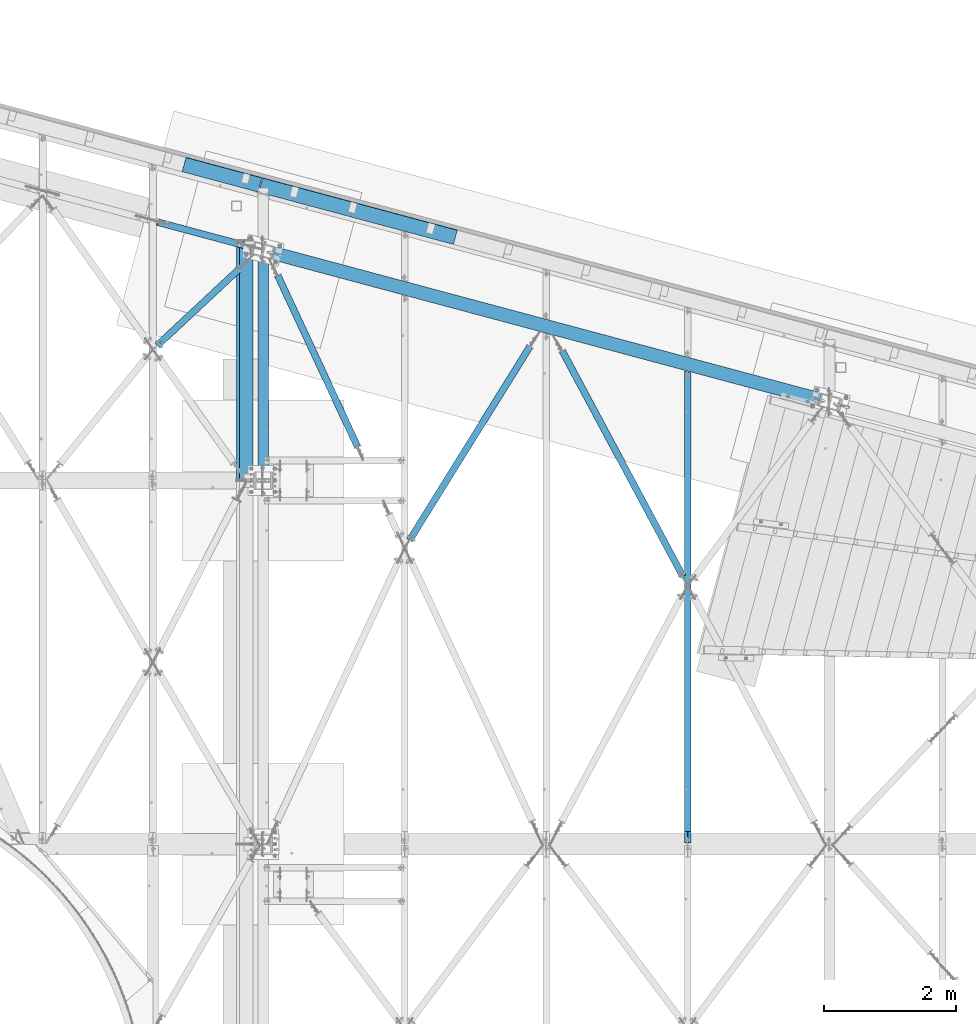
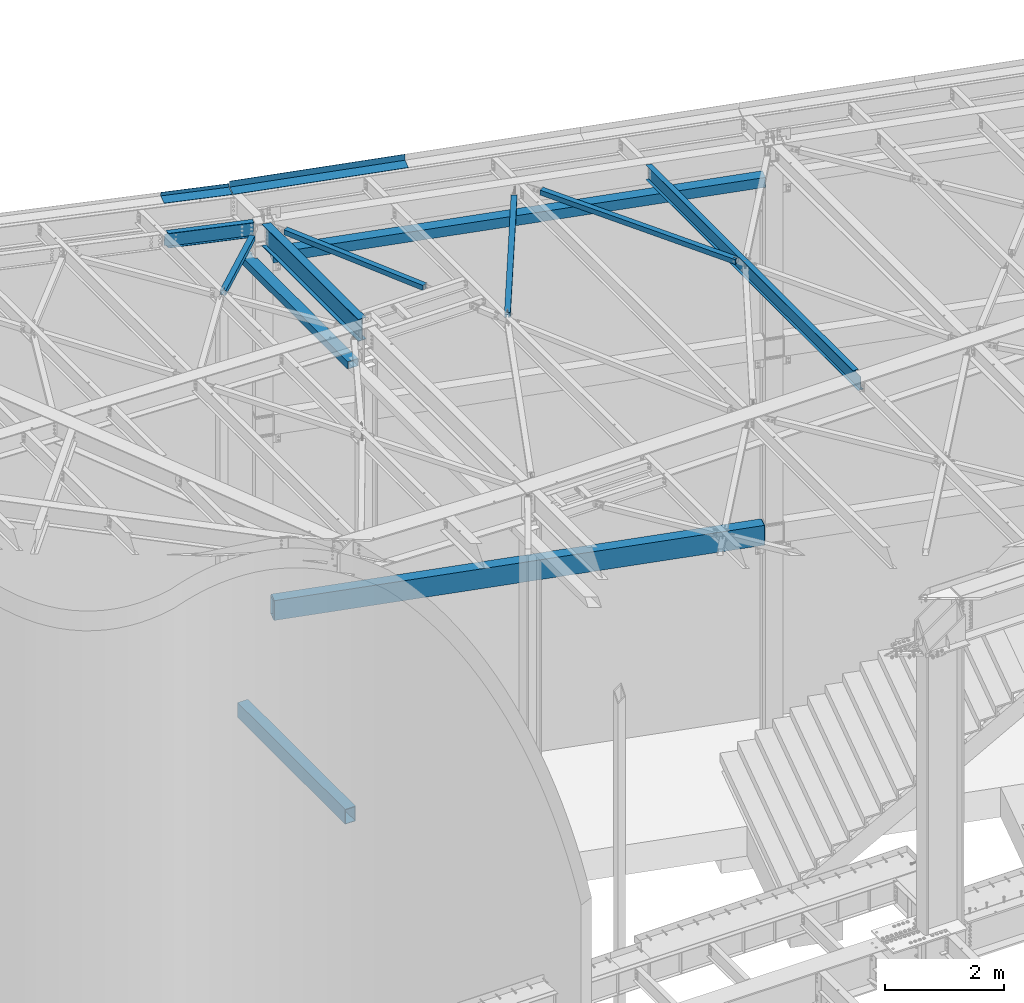
# One storey, part 1159 of 1763: 13 beams, 13 elements without a shape of their own.
"""IFC2X3 building model written with IfcOpenShell, lengths in millimetres."""

from ifc_helpers import new_model, si_unit, frame, origin_with_axes, place, context, subcontext, project, spatial, faceted_brep, material, type_object, element, aggregate, save


model = new_model("IFC2X3")

# Units and contexts
model_context = context("Model", 3, precision=1e-05, world=origin_with_axes())
body_context = subcontext(model_context, "Body", "Model", "MODEL_VIEW")
ifc_project = project(units=[si_unit("LENGTHUNIT", "METRE", prefix="MILLI"), si_unit("AREAUNIT", "SQUARE_METRE"), si_unit("VOLUMEUNIT", "CUBIC_METRE"), si_unit("MASSUNIT", "GRAM", prefix="KILO"), si_unit("TIMEUNIT", "SECOND"), si_unit("PLANEANGLEUNIT", "RADIAN"), si_unit("SOLIDANGLEUNIT", "STERADIAN"), si_unit("THERMODYNAMICTEMPERATUREUNIT", "DEGREE_CELSIUS"), si_unit("LUMINOUSINTENSITYUNIT", "LUMEN")], contexts=[model_context])

# Site, building, storey
site_placement = place(None, origin_with_axes())
site = spatial("IfcSite", under=ifc_project, at=site_placement, CompositionType="ELEMENT")
building_placement = place(site_placement, origin_with_axes())
building = spatial("IfcBuilding", under=site, at=building_placement, Name="Undefined", CompositionType="ELEMENT")
storey_placement = place(building_placement, origin_with_axes())
storey = spatial("IfcBuildingStorey", under=building, at=storey_placement, Name="Undefined", CompositionType="ELEMENT", Elevation=0.0)

# Assembly, beam
assembly_1_placement = place(storey_placement, origin_with_axes())
assembly_1 = element("IfcElementAssembly", 1, at=assembly_1_placement, inside=storey, Name="BEAM", AssemblyPlace="NOTDEFINED", PredefinedType="RIGID_FRAME")
ifc_material_1 = material()
beam_type_1 = type_object("IfcBeamType", Name="HSS8X8X3/8", PredefinedType="NOTDEFINED")
beam_1_placement = place(assembly_1_placement, frame((-39672.2896173963, 66681.4025701043, 11699.875), z_axis=(0.0, 0.0, 1.0), x_axis=(0.965925826295336, -0.25881904507913, 0.0)))
beam_1 = element("IfcBeam", 2, at=beam_1_placement, type_object=beam_type_1, material=ifc_material_1, Name="BEAM", ObjectType="HSS8X8X3/8", context=body_context, shape_type="Brep", body=[
    faceted_brep([(152.404929528384, 92.0750000005864, -92.0750000000007), (152.404929527896, -92.0749999999898, -92.0750000000007), (8712.52908409735, -92.0749999837644, -92.0750000000007), (8712.52908409783, 92.0750000168191, -92.0750000000007), (152.404929527896, -92.0749999999898, 92.0750000000007), (8712.52908409735, -92.0749999837644, 92.0750000000007), (152.404929528384, 92.0750000005864, 92.0750000000007), (8712.52908409783, 92.0750000168191, 92.0750000000007), (152.404929528398, 101.600000000624, -101.6), (152.404929528398, 101.600000000624, 101.6), (8712.52908409786, 101.600000016842, 101.6), (8712.52908409786, 101.600000016842, -101.6), (152.404929527875, -101.60000000002, 101.6), (8712.52908409732, -101.59999998378, 101.6), (152.404929527875, -101.60000000002, -101.6), (8712.52908409732, -101.59999998378, -101.6)], [[[0, 1, 2, 3]], [[1, 4, 5, 2]], [[4, 6, 7, 5]], [[6, 0, 3, 7]], [[8, 9, 10, 11]], [[9, 12, 13, 10]], [[12, 14, 15, 13]], [[14, 8, 11, 15]], [[13, 15, 11, 10], [5, 7, 3, 2]], [[14, 12, 9, 8], [6, 4, 1, 0]]]),
])
aggregate(assembly_1, [beam_1])

assembly_2_placement = place(storey_placement, origin_with_axes())
assembly_2 = element("IfcElementAssembly", 3, at=assembly_2_placement, inside=storey, Name="BEAM", AssemblyPlace="NOTDEFINED", PredefinedType="RIGID_FRAME")
beam_type_2 = type_object("IfcBeamType", Name="HSS16X8X5/8", PredefinedType="NOTDEFINED")
beam_2_placement = place(assembly_2_placement, frame((-39672.2896174423, 66681.4025701167, 4470.4), z_axis=(0.0, 0.0, 1.0), x_axis=(0.965925826295336, -0.25881904507913, 0.0)))
beam_2 = element("IfcBeam", 4, at=beam_2_placement, type_object=beam_type_2, material=ifc_material_1, Name="BEAM", ObjectType="HSS16X8X5/8", context=body_context, shape_type="Brep", body=[
    faceted_brep([(174.629929660281, 101.600000000712, 203.2), (174.629929640418, 101.600000000726, -203.2), (158.754929640003, 85.7250000006388, -187.325), (158.754929640003, 85.7250000006388, 187.325), (174.629929639552, -101.599999999729, -203.2), (158.754929640003, -85.7249999997366, -187.325), (174.629929646464, -101.600000007791, 203.200000005744), (158.754929640003, -85.7249999997366, 187.325), (8704.59949159464, -85.7249999754858, -187.325), (8688.72449160701, -101.599999975559, -203.2), (8688.7244915844, 101.600000024882, -203.2), (8704.59949159464, 85.7250000248896, -187.325), (8704.59949160298, -85.7249999917767, 187.324999992047), (8688.72449157427, -101.599999975573, 203.2), (8704.59949159464, 85.7250000248896, 187.325), (8688.72449157427, 101.600000024882, 203.2)], [[[0, 1, 2, 3]], [[4, 5, 2, 1]], [[6, 7, 5, 4]], [[8, 9, 10, 11]], [[12, 13, 9, 8]], [[14, 15, 13, 12]], [[13, 15, 0, 6]], [[9, 13, 6, 4]], [[10, 9, 4, 1]], [[15, 10, 1, 0]], [[14, 11, 10, 15]], [[11, 14, 3, 2]], [[8, 11, 2, 5]], [[12, 8, 5, 7]], [[14, 12, 7, 3]], [[0, 3, 7, 6]]]),
])
aggregate(assembly_2, [beam_2])

assembly_3_placement = place(storey_placement, origin_with_axes())
assembly_3 = element("IfcElementAssembly", 5, at=assembly_3_placement, inside=storey, Name="H. BRACE", AssemblyPlace="NOTDEFINED", PredefinedType="RIGID_FRAME")
beam_type_3 = type_object("IfcBeamType", Name="HSS4X4X3/8", PredefinedType="NOTDEFINED")
beam_3_placement = place(assembly_3_placement, frame((-38149.0745035581, 63506.3499999925, 12371.3875), z_axis=(0.0, 0.0, 1.0), x_axis=(-0.422551799059311, 0.906338776127194, 0.0)))
beam_3 = element("IfcBeam", 6, at=beam_3_placement, type_object=beam_type_3, material=ifc_material_1, Name="H. BRACE", ObjectType="HSS4X4X3/8", context=body_context, shape_type="Brep", body=[
    faceted_brep([(227.966473996188, 41.2749999993148, -41.2749999999996), (227.966473996188, -41.2750000005753, -41.2749999999996), (3079.83416805277, -41.2750000083643, -41.2749999999996), (3079.83416797796, 41.2749999915186, -41.2749999999996), (227.966473996188, -41.2750000005753, 41.2749999999996), (3079.83416805277, -41.2750000083643, 41.2749999999996), (227.966473996188, 41.2749999993148, 41.2749999999996), (3079.83416797796, 41.2749999915186, 41.2749999999996), (227.966473996188, 50.7999999993017, -50.7999999999993), (227.966473996188, 50.7999999993017, 50.7999999999993), (3079.83416796933, 50.7999999915128, 50.7999999999993), (3079.83416796933, 50.7999999915128, -50.7999999999993), (227.966473996188, -50.800000000555, 50.7999999999993), (3079.8341680614, -50.8000000083475, 50.7999999999993), (227.966473996188, -50.800000000555, -50.7999999999993), (3079.8341680614, -50.8000000083475, -50.7999999999993)], [[[0, 1, 2, 3]], [[1, 4, 5, 2]], [[4, 6, 7, 5]], [[6, 0, 3, 7]], [[8, 9, 10, 11]], [[9, 12, 13, 10]], [[12, 14, 15, 13]], [[14, 8, 11, 15]], [[13, 15, 11, 10], [5, 7, 3, 2]], [[14, 12, 9, 8], [6, 4, 1, 0]]]),
])
aggregate(assembly_3, [beam_3])

assembly_4_placement = place(storey_placement, origin_with_axes())
assembly_4 = element("IfcElementAssembly", 7, at=assembly_4_placement, inside=storey, Name="H. BRACE", AssemblyPlace="NOTDEFINED", PredefinedType="RIGID_FRAME")
beam_4_placement = place(assembly_4_placement, frame((-33252.4396171231, 61613.3086276461, 12371.3875), z_axis=(0.0, 0.0, 1.0), x_axis=(-0.471735585214394, 0.881740062400724, 0.0)))
beam_4 = element("IfcBeam", 8, at=beam_4_placement, type_object=beam_type_3, material=ifc_material_1, Name="H. BRACE", ObjectType="HSS4X4X3/8", context=body_context, shape_type="Brep", body=[
    faceted_brep([(155.52652332226, 6.35000247701464, 50.7999999999993), (155.52652332226, 6.35000247701464, 41.2749999999996), (233.119734693653, 6.34999997572231, 41.2749999999996), (233.119734693653, 6.34999997572231, 50.7999999999993), (233.11973428425, -6.35000002432571, 50.7999999999993), (233.11973428425, -6.35000002432571, 41.2749999999996), (155.52652332226, -6.34999752304066, 41.2749999999996), (155.52652332226, -6.34999752304066, 50.7999999999993), (155.52652332226, 6.35000247701464, -41.2749999999996), (155.52652332226, 6.35000247701464, -50.7999999999993), (233.119734693653, 6.34999997572231, -50.7999999999993), (233.119734693653, 6.34999997572231, -41.2749999999996), (233.11973428425, -6.35000002432571, -41.2749999999996), (233.11973428425, -6.35000002432571, -50.7999999999993), (155.52652332226, -6.34999752304066, -50.7999999999993), (155.52652332226, -6.34999752304066, -41.2749999999996), (155.52652332226, -41.2750000005617, -41.2749999999996), (155.52652332226, -41.2750000005617, 41.2749999999996), (4016.93462155541, -41.2750000137494, 41.2749999999996), (4016.93462155541, -41.2750000137494, -41.2749999999996), (155.52652332226, 50.7999999995045, -50.7999999999993), (4016.93462155541, 50.7999999863132, -50.7999999999993), (4016.93462155541, -50.8000000137581, -50.7999999999993), (155.52652332226, -50.8000000005704, -50.7999999999993), (155.52652332226, -50.8000000005704, 50.7999999999993), (4016.93462155541, -50.8000000137581, 50.7999999999993), (155.52652332226, 41.2749999994958, 41.2749999999996), (4016.93462155541, 41.2749999863117, 41.2749999999996), (155.52652332226, 41.2749999994958, -41.2749999999996), (4016.93462155541, 41.2749999863117, -41.2749999999996), (4016.93462155541, 50.7999999863132, 50.7999999999993), (155.52652332226, 50.7999999995045, 50.7999999999993)], [[[0, 1, 2, 3]], [[4, 5, 6, 7]], [[3, 2, 5, 4]], [[8, 9, 10, 11]], [[12, 13, 14, 15]], [[11, 10, 13, 12]], [[16, 17, 18, 19]], [[9, 20, 21, 22, 23, 14, 13, 10]], [[24, 23, 22, 25]], [[17, 16, 15, 14, 23, 24, 7, 6]], [[1, 26, 27, 18, 17, 6, 5, 2]], [[26, 28, 29, 27]], [[25, 22, 21, 30], [18, 27, 29, 19]], [[20, 31, 30, 21]], [[24, 25, 30, 31, 0, 3, 4, 7]], [[31, 20, 9, 8, 28, 26, 1, 0]], [[16, 19, 29, 28, 8, 11, 12, 15]]]),
])
aggregate(assembly_4, [beam_4])

assembly_5_placement = place(storey_placement, origin_with_axes())
assembly_5 = element("IfcElementAssembly", 9, at=assembly_5_placement, inside=storey, Name="H. BRACE", AssemblyPlace="NOTDEFINED", PredefinedType="RIGID_FRAME")
beam_5_placement = place(assembly_5_placement, frame((-39721.2091356066, 66694.510515489, 12382.5), z_axis=(0.0, 0.0, 1.0), x_axis=(-0.730932691702621, -0.682449558722372, 0.0)))
beam_5 = element("IfcBeam", 10, at=beam_5_placement, type_object=beam_type_3, material=ifc_material_1, Name="H. BRACE", ObjectType="HSS4X4X3/8", context=body_context, shape_type="Brep", body=[
    faceted_brep([(2126.16793068792, 6.3500000040076, 50.7999999999993), (2048.38043068183, 6.35000000408036, 50.7999999999993), (2048.38043068183, 6.35000000408036, 41.2749999999996), (2126.16793068792, 6.3500000040076, 41.2749999999996), (2048.38043068182, -6.34999999585852, 50.7999999999993), (2048.38043068182, -6.34999999585852, 41.2749999999996), (2126.16793068792, -6.34999999593128, 50.7999999999993), (2126.16793068792, -6.34999999593128, 41.2749999999996), (2126.16793068792, 6.3500000040076, -41.2749999999996), (2048.38043068183, 6.35000000408036, -41.2749999999996), (2048.38043068183, 6.35000000408036, -50.7999999999993), (2126.16793068792, 6.3500000040076, -50.7999999999993), (2048.38043068182, -6.34999999585852, -41.2749999999996), (2048.38043068182, -6.34999999585852, -50.7999999999993), (2126.16793068792, -6.34999999593128, -41.2749999999996), (2126.16793068792, -6.34999999593128, -50.7999999999993), (446.776849324, 41.2749999995867, 41.2749999999996), (446.776849324, 41.2749999995867, -41.2749999999996), (2126.16793068792, 41.2749999982043, -41.2749999999996), (2126.16793068792, 41.2749999982043, 41.2749999999996), (2126.16793068792, -41.2750000016531, 41.2749999999996), (446.776849324, -41.2750000002998, 41.2749999999996), (446.776849324, -41.2750000002998, -41.2749999999996), (2126.16793068792, -41.2750000016531, -41.2749999999996), (446.776849323996, -50.8000000002794, -50.7999999999993), (446.776849323996, -50.8000000002794, 50.7999999999993), (446.776849324, 50.7999999995518, 50.7999999999993), (446.776849324, 50.7999999995518, -50.7999999999993), (2126.16793068792, 50.7999999981985, 50.7999999999993), (2126.16793068792, 50.7999999981985, -50.7999999999993), (2126.16793068792, -50.8000000016473, -50.7999999999993), (2126.16793068792, -50.8000000016473, 50.7999999999993)], [[[0, 1, 2, 3]], [[4, 5, 2, 1]], [[6, 7, 5, 4]], [[8, 9, 10, 11]], [[12, 13, 10, 9]], [[14, 15, 13, 12]], [[16, 17, 18, 19]], [[20, 21, 16, 19, 3, 2, 5, 7]], [[22, 21, 20, 23]], [[9, 8, 18, 17, 22, 23, 14, 12]], [[24, 25, 26, 27], [16, 21, 22, 17]], [[27, 26, 28, 29]], [[19, 18, 8, 11, 29, 28, 0, 3]], [[30, 24, 27, 29, 11, 10, 13, 15]], [[25, 24, 30, 31]], [[1, 0, 28, 26, 25, 31, 6, 4]], [[31, 30, 15, 14, 23, 20, 7, 6]]]),
])
aggregate(assembly_5, [beam_5])

assembly_6_placement = place(storey_placement, origin_with_axes())
assembly_6 = element("IfcElementAssembly", 11, at=assembly_6_placement, inside=storey, Name="H. BRACE", AssemblyPlace="NOTDEFINED", PredefinedType="RIGID_FRAME")
beam_6_placement = place(assembly_6_placement, frame((-35441.4586494242, 65547.7548290334, 12371.3875), z_axis=(0.0, 0.0, 1.0), x_axis=(-0.527859501823554, -0.849331705716082, 0.0)))
beam_6 = element("IfcBeam", 12, at=beam_6_placement, type_object=beam_type_3, material=ifc_material_1, Name="H. BRACE", ObjectType="HSS4X4X3/8", context=body_context, shape_type="Brep", body=[
    faceted_brep([(3825.18437271714, 6.36887452250812, 50.7999999999993), (3747.39533194307, 6.34999974240782, 50.7999999999993), (3747.39533194307, 6.34999974240782, 41.2749999999996), (3825.18437271714, 6.36887452250812, 41.2749999999996), (3747.39841347899, -6.3499998835905, 50.7999999999993), (3747.39841347899, -6.3499998835905, 41.2749999999996), (3825.18437271722, -6.33112585106574, 50.7999999999993), (3825.18437271722, -6.33112585106574, 41.2749999999996), (3825.18437271714, 6.36887452250812, -41.2749999999996), (3747.39533194307, 6.34999974240782, -41.2749999999996), (3747.39533194307, 6.34999974240782, -50.7999999999993), (3825.18437271714, 6.36887452250812, -50.7999999999993), (3747.39841347899, -6.3499998835905, -41.2749999999996), (3747.39841347899, -6.3499998835905, -50.7999999999993), (3825.18437271722, -6.33112585106574, -41.2749999999996), (3825.18437271722, -6.33112585106574, -50.7999999999993), (382.334458302576, 41.2749999992302, 41.2749999999996), (382.334458302576, 41.2749999992302, -41.2749999999996), (3825.18437271693, 41.274999993926, -41.2749999999996), (3825.18437271693, 41.274999993926, 41.2749999999996), (3825.18437271743, -41.2750000056985, 41.2749999999996), (382.334458303085, -41.2750000003871, 41.2749999999996), (382.334458303085, -41.2750000003871, -41.2749999999996), (3825.18437271743, -41.2750000056985, -41.2749999999996), (382.334458303143, -50.8000000003376, -50.7999999999993), (382.334458303143, -50.8000000003376, 50.7999999999993), (382.334458302517, 50.799999999188, 50.7999999999993), (382.334458302517, 50.799999999188, -50.7999999999993), (3825.18437271687, 50.7999999938766, 50.7999999999993), (3825.18437271687, 50.7999999938766, -50.7999999999993), (3825.18437271749, -50.8000000056418, -50.7999999999993), (3825.18437271749, -50.8000000056418, 50.7999999999993)], [[[0, 1, 2, 3]], [[4, 5, 2, 1]], [[6, 7, 5, 4]], [[8, 9, 10, 11]], [[12, 13, 10, 9]], [[14, 15, 13, 12]], [[16, 17, 18, 19]], [[20, 21, 16, 19, 3, 2, 5, 7]], [[22, 21, 20, 23]], [[9, 8, 18, 17, 22, 23, 14, 12]], [[24, 25, 26, 27], [16, 21, 22, 17]], [[27, 26, 28, 29]], [[19, 18, 8, 11, 29, 28, 0, 3]], [[30, 24, 27, 29, 11, 10, 13, 15]], [[25, 24, 30, 31]], [[1, 0, 28, 26, 25, 31, 6, 4]], [[31, 30, 15, 14, 23, 20, 7, 6]]]),
])
aggregate(assembly_6, [beam_6])

assembly_7_placement = place(storey_placement, origin_with_axes())
assembly_7 = element("IfcElementAssembly", 13, at=assembly_7_placement, inside=storey, Name="BEAM", AssemblyPlace="NOTDEFINED", PredefinedType="RIGID_FRAME")
ifc_material_2 = material(Name="STEEL/A36")
beam_type_4 = type_object("IfcBeamType", PredefinedType="NOTDEFINED")
beam_7_placement = place(assembly_7_placement, frame((-40324.978143343, 67717.5790610837, 12468.9302367905), z_axis=(-0.965507252027915, 0.25870688944179, 0.0294362300041612), x_axis=(0.258819045079128, 0.965925826295336, 0.0)))
beam_7 = element("IfcBeam", 14, at=beam_7_placement, type_object=beam_type_4, material=ifc_material_2, Name="BENT_PLATE", context=body_context, shape_type="Brep", body=[
    faceted_brep([(-5.45696821063757e-09, -3.17499999964093, -593.829499997599), (3.83442966267467e-09, -3.17500000035761, 593.829499997591), (5.44969225302339e-09, 3.17499999964093, 593.829499997606), (-3.84170562028885e-09, 3.17500000036125, -593.829499997591), (228.599994882599, 3.17499994036189, 593.829499994121), (228.599994824435, 3.17499994108221, -593.829500001062), (222.249995283702, -3.17500005727197, -593.829500000982), (222.249995341866, -3.17500005799229, 593.829499994208), (228.60000036977, -73.0249978483589, 593.82949999097), (228.600000360522, -73.0249977987587, -593.829500004234), (222.250000369742, -73.0249983076301, 593.82949999105), (222.250000360487, -73.0249982580317, -593.82950000414)], [[[0, 1, 2, 3]], [[3, 2, 4, 5]], [[1, 0, 6, 7]], [[5, 4, 8, 9]], [[4, 2, 1, 7, 10, 8]], [[7, 6, 11, 10]], [[6, 0, 3, 5, 9, 11]], [[10, 11, 9, 8]]]),
])
aggregate(assembly_7, [beam_7])

assembly_8_placement = place(storey_placement, origin_with_axes())
assembly_8 = element("IfcElementAssembly", 15, at=assembly_8_placement, inside=storey, Name="BEAM", AssemblyPlace="NOTDEFINED", PredefinedType="RIGID_FRAME")
beam_type_5 = type_object("IfcBeamType", PredefinedType="NOTDEFINED")
beam_8_placement = place(assembly_8_placement, frame((-38267.4548363049, 67166.2673575729, 12449.175), z_axis=(-0.965925827679309, 0.258819039914073, 0.0), x_axis=(0.258819045079128, 0.965925826295336, 0.0)))
beam_8 = element("IfcBeam", 16, at=beam_8_placement, type_object=beam_type_5, material=ifc_material_2, Name="BENT_PLATE", context=body_context, shape_type="Brep", body=[
    faceted_brep([(0.0, -3.17499999999927, -1523.99999999999), (0.0, -3.17499999999927, 1524.0), (0.0, 3.17499999999927, 1524.0), (0.0, 3.17499999999927, -1523.99999999999), (228.599995165183, 3.17499993969795, 1523.99999998704), (228.599994834185, 3.17499994154787, -1524.00000000063), (222.249995293445, -3.17500005680085, -1524.00000000046), (222.249995624443, -3.17500005865077, 1523.99999998722), (228.599994977769, -123.824999999819, 1524.000000004), (228.599994986405, -123.824999999819, -1524.00000000269), (222.249994977741, -123.824999999819, 1524.00000000397), (222.249994986378, -123.824999999819, -1524.00000000271)], [[[0, 1, 2, 3]], [[3, 2, 4, 5]], [[1, 0, 6, 7]], [[5, 4, 8, 9]], [[4, 2, 1, 7, 10, 8]], [[7, 6, 11, 10]], [[6, 0, 3, 5, 9, 11]], [[10, 11, 9, 8]]]),
])
aggregate(assembly_8, [beam_8])

assembly_9_placement = place(storey_placement, origin_with_axes())
assembly_9 = element("IfcElementAssembly", 17, at=assembly_9_placement, inside=storey, Name="BEAM", AssemblyPlace="NOTDEFINED", PredefinedType="RIGID_FRAME")
ifc_material_3 = material(Name="STEEL/A992")
beam_type_6 = type_object("IfcBeamType", Name="W12X16", PredefinedType="NOTDEFINED")
beam_9_placement = place(assembly_9_placement, frame((-33252.4396174484, 57702.45, 12293.6), z_axis=(0.0, 0.0, 1.0), x_axis=(0.0, 1.0, 0.0)))
beam_9 = element("IfcBeam", 18, at=beam_9_placement, type_object=beam_type_6, material=ifc_material_3, Name="BEAM", ObjectType="W12X16", context=body_context, shape_type="Brep", body=[
    faceted_brep([(20.637499999335, -3.17500000023574, -146.050000000019), (20.637499999335, -50.8000000002503, -146.05000000003), (7126.81506091975, -50.8000000000029, -146.049999999999), (7139.57614120804, -3.17500000000291, -146.049999999999), (20.637499999335, -50.8000000002576, -152.400000000032), (7126.81506091975, -50.8000000000029, -152.4), (20.637499999335, 50.7999999997701, -152.400000000003), (7154.03869886811, 50.8000000000029, -152.4), (20.637499999335, 50.7999999997774, -146.050000000005), (7154.03869886811, 50.8000000000029, -146.049999999999), (7141.27761857981, 3.17500000000291, -146.049999999999), (7141.27761857981, 3.17500000000291, 146.049999999999), (7154.03869886811, 50.8000000000029, 146.049999999999), (7154.03869886811, 50.8000000000029, 152.4), (7126.81506091975, -50.8000000000029, 152.4), (7126.81506091975, -50.8000000000029, 146.049999999999), (7139.57614120804, -3.17500000000291, 146.049999999999), (20.637499999335, 3.17499999977008, -146.050000000016), (184.247579708775, -3.17500000000291, 115.006731601054), (184.247579708775, 3.17500000000291, 115.006731601054), (179.387500190729, 3.17500000000291, 114.040001678466), (179.387500190729, -3.17500000000291, 114.040001678466), (188.367756176929, -3.17500000000291, 117.759745501531), (188.367756176929, 3.17500000000291, 117.759745501531), (191.120770077403, -3.17500000000291, 121.879921969685), (191.120770077403, 3.17500000000291, 121.879921969685), (192.087499999994, -3.17500000000291, 126.740001487731), (192.087499999994, 3.17500000000291, 126.740001487731), (20.6374999999971, 3.17500000000291, 114.040001678466), (192.087499999994, 3.17500000000291, 146.049999999999), (192.087499999994, 50.8000000000029, 146.049999999999), (192.087499999994, 50.8000000000029, 152.4), (192.087499999994, -50.8000000000029, 152.4), (192.087499999994, -50.8000000000029, 146.049999999999), (192.087499999994, -3.17500000000291, 146.049999999999), (20.6374999999971, -3.17500000000291, 114.040001678466)], [[[0, 1, 2, 3]], [[1, 4, 5, 2]], [[4, 6, 7, 5]], [[6, 8, 9, 7]], [[10, 11, 12, 13, 14, 15, 16, 3, 2, 5, 7, 9]], [[8, 17, 10, 9]], [[18, 19, 20, 21]], [[22, 23, 19, 18]], [[24, 25, 23, 22]], [[26, 27, 25, 24]], [[11, 10, 17, 28, 20, 19, 23, 25, 27, 29]], [[12, 11, 29, 30]], [[13, 12, 30, 31]], [[14, 13, 31, 32]], [[15, 14, 32, 33]], [[16, 15, 33, 34]], [[32, 31, 30, 29, 27, 26, 34, 33]], [[24, 22, 18, 21, 35, 0, 3, 16, 34, 26]], [[17, 8, 6, 4, 1, 0, 35, 28]], [[21, 20, 28, 35]]]),
])
aggregate(assembly_9, [beam_9])

assembly_10_placement = place(storey_placement, origin_with_axes())
assembly_10 = element("IfcElementAssembly", 19, at=assembly_10_placement, inside=storey, Name="BEAM", AssemblyPlace="NOTDEFINED", PredefinedType="RIGID_FRAME")
beam_type_7 = type_object("IfcBeamType", Name="W18X35", PredefinedType="NOTDEFINED")
beam_10_placement = place(assembly_10_placement, frame((-39672.2896174484, 63201.55, 12220.575), z_axis=(0.0, 0.0, 1.0), x_axis=(0.0, 1.0, 0.0)))
beam_10 = element("IfcBeam", 20, at=beam_10_placement, type_object=beam_type_7, material=ifc_material_3, Name="BEAM", ObjectType="W18X35", context=body_context, shape_type="Brep", body=[
    faceted_brep([(3359.22741898826, 3.96875, -214.3125), (3339.50515112709, 3.96875, -214.3125), (3337.37789162382, -3.96875, -214.3125), (3357.10015948501, -3.96875, -214.3125), (3324.37069866859, 3.96875000058208, -209.649366388161), (3322.24343916516, -3.96875, -209.649366388161), (3321.05457302539, 3.96875000058208, -206.213417228089), (3318.92731352197, -3.96875, -206.213417228089), (3319.85087530532, 3.96875000058208, -201.662182817299), (3317.72361580191, -3.96875, -201.662182817299), (3321.05457302539, 3.96875000058208, -197.110948406509), (3318.92731352197, -3.96875, -197.110948406509), (3324.37069866859, 3.96875000058208, -193.674999246437), (3322.24343916516, -3.96875, -193.674999246437), (3329.67808251728, 3.96875000058208, -192.087497720559), (3327.55082301385, -3.96875, -192.087497720559), (3362.58259071123, 3.96875, -192.08749009293), (3360.45533120797, -3.96875, -192.08749009293), (144.462499999994, 76.1999999999971, 225.424999999999), (144.462499999994, -76.1999999999971, 225.424999999999), (3337.74209800106, -76.1999999999971, 225.424999999999), (3378.58548046369, 76.1999999999971, 225.424999999999), (3358.86321259708, 76.1999999999971, 214.3125), (144.462499999994, 76.1999999999971, 214.3125), (3385.22769677997, 76.1999999999971, 214.3125), (3339.50515111738, 3.96875, 214.3125), (144.462499999994, 3.96875, 214.3125), (3365.86963530093, 3.96874999982538, 214.3125), (3318.01983014414, -76.1999999999971, -214.3125), (144.462499999994, -76.1999999999971, -214.3125), (144.462499999994, -76.1999999999971, -225.424999999999), (3344.38431432161, -76.1999999999971, -225.424999999999), (3337.74209800531, -76.1999999999971, -214.3125), (144.462499999994, 76.1999999999971, -225.424999999999), (3385.22769678423, 76.1999999999971, -225.424999999999), (144.462499999994, 76.1999999999971, -214.3125), (3358.86321260677, 76.1999999999971, -214.3125), (3378.58548046795, 76.1999999999971, -214.3125), (144.462499999994, -3.96875, -214.3125), (144.462499999994, -3.96875, 214.3125), (144.462499999994, -76.1999999999971, 214.3125), (144.462499999994, 3.96875, -214.3125), (3318.01983013444, -76.1999999999971, 214.3125), (3344.38431431734, -76.1999999999971, 214.3125), (3363.74237579702, -3.96875, 214.3125), (3337.37789161413, -3.96875, 214.3125), (3322.24343915547, -3.96875, 209.649366378784), (3324.37069865873, 3.96875, 209.649366378784), (3318.92731351228, -3.96875, 206.213417218712), (3321.05457301554, 3.96875, 206.213417218712), (3317.7236157922, -3.96875, 201.662182807922), (3319.85087529547, 3.96875, 201.662182807922), (3318.92731351228, -3.96875, 197.110948397132), (3321.05457301554, 3.96875, 197.110948397132), (3322.24343915547, -3.96875, 193.674999237061), (3324.37069865873, 3.96875, 193.674999237061), (3327.55082300416, -3.96875, 192.087497711182), (3329.67808250742, 3.96875, 192.087497711182), (3360.45533120769, -3.96875, 192.087497711182), (3362.58259071095, 3.96875, 192.087497711182)], [[[0, 1, 2, 3]], [[4, 5, 2, 1]], [[6, 7, 5, 4]], [[8, 9, 7, 6]], [[10, 11, 9, 8]], [[12, 13, 11, 10]], [[14, 15, 13, 12]], [[16, 17, 15, 14]], [[18, 19, 20, 21]], [[22, 23, 18, 21, 24]], [[25, 26, 23, 22, 24, 27]], [[28, 29, 30, 31, 32]], [[30, 33, 34, 31]], [[33, 35, 36, 37, 34]], [[30, 29, 38, 39, 40, 19, 18, 23, 26, 41, 35, 33]], [[19, 40, 42, 43, 20]], [[24, 21, 20, 43, 44, 27]], [[42, 40, 39, 45, 44, 43]], [[27, 44, 45, 25]], [[25, 45, 46, 47]], [[47, 46, 48, 49]], [[49, 48, 50, 51]], [[51, 50, 52, 53]], [[53, 52, 54, 55]], [[55, 54, 56, 57]], [[57, 56, 58, 59]], [[12, 10, 8, 6, 4, 1, 41, 26, 25, 47, 49, 51, 53, 55, 57, 59, 16, 14]], [[36, 35, 41, 1, 0, 37]], [[32, 31, 34, 37, 0, 3]], [[2, 38, 29, 28, 32, 3]], [[58, 56, 54, 52, 50, 48, 46, 45, 39, 38, 2, 5, 7, 9, 11, 13, 15, 17]], [[59, 58, 17, 16]]]),
])
aggregate(assembly_10, [beam_10])

assembly_11_placement = place(storey_placement, origin_with_axes())
assembly_11 = element("IfcElementAssembly", 21, at=assembly_11_placement, inside=storey, Name="BEAM", AssemblyPlace="NOTDEFINED", PredefinedType="RIGID_FRAME")
beam_type_8 = type_object("IfcBeamType", Name="W12X14", PredefinedType="NOTDEFINED")
beam_11_placement = place(assembly_11_placement, frame((-41342.8263060585, 67129.0215268429, 12346.0531748704), z_axis=(0.0284332150015107, -0.00761865702657088, 0.99956666028324), x_axis=(0.965507252136511, -0.258706889036504, -0.029436230004148)))
beam_11 = element("IfcBeam", 22, at=beam_11_placement, type_object=beam_type_8, material=ifc_material_3, Name="BEAM", ObjectType="W12X14", context=body_context, shape_type="Brep", body=[
    faceted_brep([(16.8464433371992, -2.3812500002241, -119.184015074197), (16.8464431397006, 2.38124999977299, -119.184015073679), (51.7136591015151, 2.38124999977299, -119.184015067218), (52.9891751532705, -2.38125000021682, -119.18401506748), (56.7480720471212, 2.38124999978754, -120.151963644124), (58.0235880988766, -2.38125000020227, -120.151963644388), (61.0150750838511, 2.38124999977299, -122.90826221729), (62.2905911356065, -2.38125000020955, -122.908262217554), (63.8642367812499, 2.38124999975844, -127.032760341981), (65.1397528330126, -2.38125000021682, -127.032760342245), (64.8612513039916, 2.38124999975116, -131.896749017536), (66.1367673557397, -2.38125000023138, -131.896749017802), (79.0914702861264, -50.800000000112, -144.462500000076), (66.1237237599198, -2.3812500002532, -144.462500000043), (64.8482077081644, 2.38124999973661, -144.46250000004), (51.8804611819505, 50.7999999995882, -144.462500000007), (51.8738697069857, 50.7999999995809, -150.812500000007), (79.0848788111616, -50.8000000001193, -150.812500000076), (1560.78829729285, -50.7999999991298, 144.462499999907), (1560.60129619095, -50.799999999108, 150.812499999909), (79.3979654510913, -50.7999999995372, 150.812499999996), (79.3913741192009, -50.7999999995664, 144.462499999994), (1560.606227962, 50.8000000006068, 150.812499999976), (52.1869563469008, 50.800000000163, 150.812500000065), (1560.79322906389, 50.800000000585, 144.462499999974), (52.1803650150177, 50.800000000163, 144.462500000065), (1560.79087876675, 2.38125000071886, 144.462499999941), (65.1481115412316, 2.38125000029686, 144.462500000032), (53.2560497634477, -2.38124999976571, 112.521346203497), (51.9805337116995, 2.3812500002241, 112.521346203759), (17.0869528923577, 2.3812500002241, 112.521346196943), (17.0869529041665, -2.38124999976571, 112.521346196427), (58.2843730468376, -2.38124999975116, 113.486858235472), (57.0088569950894, 2.38125000023865, 113.486858235736), (62.5481440937729, -2.38124999975116, 116.236589054386), (61.2726280420102, 2.38125000023865, 116.23658905465), (65.3990601789701, -2.38124999973661, 120.35244445117), (64.1235441272293, 2.38125000023865, 120.352444451431), (66.4036419605982, -2.38124999972933, 125.208612148139), (65.1281259088501, 2.3812500002532, 125.208612148401), (66.4236275929943, -2.38124999970023, 144.462500000029), (1560.79064758999, -2.38124999927095, 144.462499999938), (1569.29942890302, 2.38125000016589, -144.462500000131), (1569.29919772626, -2.38124999981665, -144.462500000136), (1569.29684742913, -50.79999999969, -144.462500000169), (1569.48384853101, -50.7999999996973, -150.812500000167), (1569.48878030206, 50.8000000000247, -150.812500000102), (1569.30177920016, 50.8000000000247, -144.462500000098)], [[[0, 1, 2, 3]], [[3, 2, 4, 5]], [[5, 4, 6, 7]], [[7, 6, 8, 9]], [[9, 8, 10, 11]], [[12, 13, 11, 10, 14, 15, 16, 17]], [[18, 19, 20, 21]], [[19, 22, 23, 20]], [[22, 24, 25, 23]], [[24, 26, 27, 25]], [[28, 29, 30, 31]], [[32, 33, 29, 28]], [[34, 35, 33, 32]], [[36, 37, 35, 34]], [[38, 39, 37, 36]], [[20, 23, 25, 27, 39, 38, 40, 21]], [[41, 18, 21, 40]], [[42, 26, 24, 22, 19, 18, 41, 43, 44, 45, 46, 47]], [[45, 44, 12, 17]], [[46, 45, 17, 16]], [[47, 46, 16, 15]], [[42, 47, 15, 14]], [[6, 4, 2, 1, 30, 29, 33, 35, 37, 39, 27, 26, 42, 14, 10, 8]], [[31, 30, 1, 0]], [[43, 41, 40, 38, 36, 34, 32, 28, 31, 0, 3, 5, 7, 9, 11, 13]], [[44, 43, 13, 12]]]),
])
aggregate(assembly_11, [beam_11])

assembly_12_placement = place(storey_placement, origin_with_axes())
assembly_12 = element("IfcElementAssembly", 23, at=assembly_12_placement, inside=storey, Name="BEAM", AssemblyPlace="NOTDEFINED", PredefinedType="RIGID_FRAME")
beam_type_9 = type_object("IfcBeamType", Name="HSS8X6X3/8", PredefinedType="NOTDEFINED")
beam_12_placement = place(assembly_12_placement, frame((-39926.2896174484, 63201.55, 11684.0), z_axis=(-1.0, 0.0, 0.0), x_axis=(0.0, 1.0, 0.0)))
beam_12 = element("IfcBeam", 24, at=beam_12_placement, type_object=beam_type_9, material=ifc_material_1, Name="BEAM", ObjectType="HSS8X6X3/8", context=body_context, shape_type="Brep", body=[
    faceted_brep([(3402.81100000582, 66.6749999999993, -63.4996162445022), (3402.81100000582, 76.2000000000007, -63.4996162445022), (3567.91099086418, 76.2000000000007, -63.4996184237461), (3567.91099086418, 66.6749999999993, -63.4996184237461), (3402.8105250082, -76.2000000000007, -101.599999999999), (3402.8105250082, 76.2000000000007, -101.599999999999), (3402.81064375662, 66.6749999999993, -92.0749999999971), (3402.81064375662, -66.6749999999993, -92.0749999999971), (3402.81100000582, -66.6749999999993, -63.4996162445022), (3402.81100000582, -76.2000000000007, -63.4996162445022), (3567.91099086418, -66.6749999999993, -63.4996184237461), (3567.91099086418, -76.2000000000007, -63.4996184237461), (3567.91063461472, -66.6749999999993, -92.0749999999971), (3567.91063461472, 66.6749999999993, -92.0749999999971), (3567.91051586658, 76.2000000000007, -101.599999999999), (3567.91051586658, -76.2000000000007, -101.599999999999), (3623.07187500001, 76.2000000000007, -101.599999999999), (3623.07187500001, -76.2000000000007, -101.599999999999), (9.52500000000146, 76.2000000000007, 101.599999999999), (9.52500000000146, -76.2000000000007, 101.599999999999), (3623.07187500001, -76.2000000000007, 101.599999999999), (3623.07187500001, 76.2000000000007, 101.599999999999), (9.52500000000146, -76.2000000000007, -101.599999999999), (9.52500000000146, 76.2000000000007, -101.599999999999), (3623.07187500001, -66.6749999999993, 92.0749999999971), (3623.07187500001, 66.6749999999993, 92.0749999999971), (3623.07187500001, 66.6749999999993, -92.0749999999971), (3623.07187500001, -66.6749999999993, -92.0749999999971), (9.52500000000146, -66.6749999999993, 92.0749999999971), (9.52500000000146, 66.6749999999993, 92.0749999999971), (9.52500000000146, -66.6749999999993, -92.0749999999971), (9.52500000000146, 66.6749999999993, -92.0749999999971)], [[[0, 1, 2, 3]], [[4, 5, 1, 0, 6, 7, 8, 9]], [[9, 8, 10, 11]], [[11, 10, 12, 13, 3, 2, 14, 15]], [[16, 17, 15, 14]], [[18, 19, 20, 21]], [[22, 23, 5, 4]], [[17, 20, 19, 22, 4, 9, 11, 15]], [[5, 23, 18, 21, 16, 14, 2, 1]], [[20, 17, 16, 21], [24, 25, 26, 27]], [[28, 29, 25, 24]], [[22, 19, 18, 23], [29, 28, 30, 31]], [[31, 30, 7, 6]], [[26, 25, 29, 31, 6, 0, 3, 13]], [[27, 26, 13, 12]], [[7, 30, 28, 24, 27, 12, 10, 8]]]),
])
aggregate(assembly_12, [beam_12])

assembly_13_placement = place(storey_placement, origin_with_axes())
assembly_13 = element("IfcElementAssembly", 25, at=assembly_13_placement, inside=storey, Name="BEAM", AssemblyPlace="NOTDEFINED", PredefinedType="RIGID_FRAME")
beam_type_10 = type_object("IfcBeamType", Name="HSS12X8X3/8", PredefinedType="NOTDEFINED")
beam_13_placement = place(assembly_13_placement, frame((-39977.0896174484, 63201.55, 2451.1), z_axis=(0.0, 0.0, 1.0), x_axis=(0.0, 1.0, 0.0)))
beam_13 = element("IfcBeam", 26, at=beam_13_placement, type_object=beam_type_10, material=ifc_material_1, Name="BEAM", ObjectType="HSS12X8X3/8", context=body_context, shape_type="Brep", body=[
    faceted_brep([(9.52500000000146, 92.0749999999971, -142.875), (9.52500000000146, -92.0749999999971, -142.875), (3623.07187500002, -92.0749999999971, -142.875), (3623.07187500002, 92.0749999999971, -142.875), (9.52500000000146, -92.0749999999971, 142.875), (3623.07187500002, -92.0749999999971, 142.875), (9.52500000000146, 92.0749999999971, 142.875), (3623.07187500002, 92.0749999999971, 142.875), (9.52500000000146, 101.599999999999, -152.4), (9.52500000000146, 101.599999999999, 152.4), (3623.07187500002, 101.599999999999, 152.4), (3623.07187500002, 101.599999999999, -152.4), (9.52500000000146, -101.599999999999, 152.4), (3623.07187500002, -101.599999999999, 152.4), (9.52500000000146, -101.599999999999, -152.4), (3623.07187500002, -101.599999999999, -152.4)], [[[0, 1, 2, 3]], [[1, 4, 5, 2]], [[4, 6, 7, 5]], [[6, 0, 3, 7]], [[8, 9, 10, 11]], [[9, 12, 13, 10]], [[12, 14, 15, 13]], [[14, 8, 11, 15]], [[13, 15, 11, 10], [5, 7, 3, 2]], [[14, 12, 9, 8], [6, 4, 1, 0]]]),
])
aggregate(assembly_13, [beam_13])

save(model, "model.ifc")
